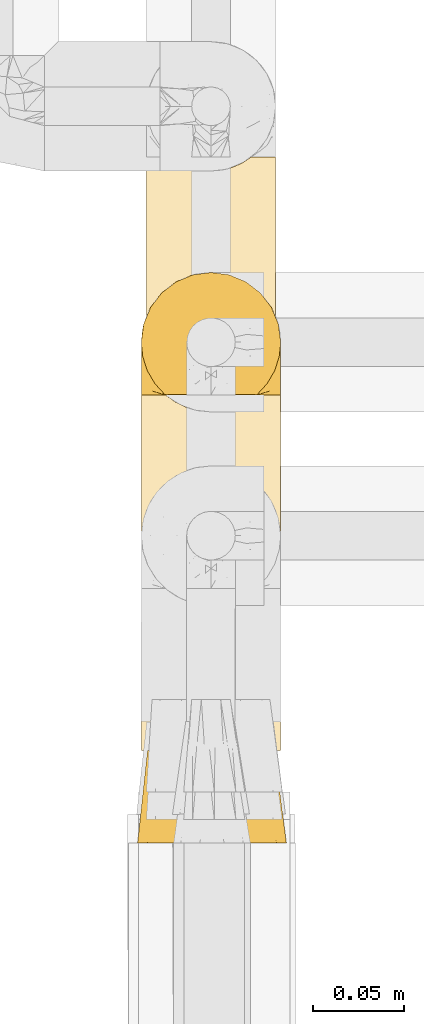
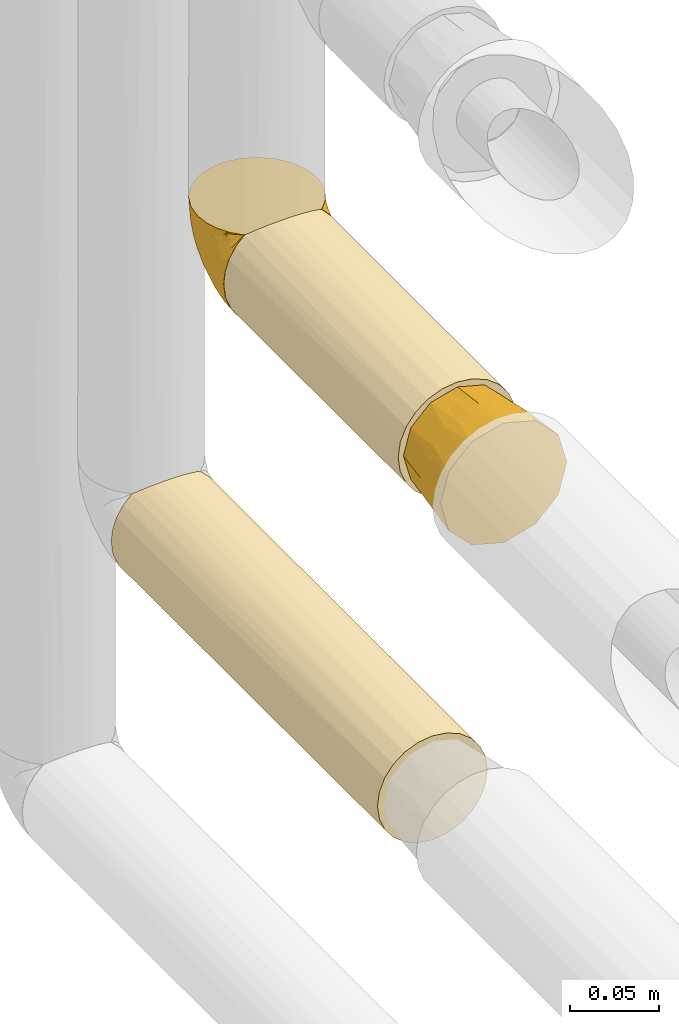
# One storey, part 78 of 827: 4 coverings.
"""IFC2X3 building model written with IfcOpenShell, lengths in millimetres."""

from ifc_helpers import new_model, entity, si_unit, converted_unit, derived_unit, direction, frame, origin, place, context, subcontext, project, spatial, faceted_brep, element, save


model = new_model("IFC2X3")

# Units and contexts
model_context = context("Model", 3, precision=0.01, world=origin(), true_north=direction((6.12303176911189e-17, 1.0)))
body_context = subcontext(model_context, "Body", "Model", "MODEL_VIEW")
ifc_project = project(units=[si_unit("LENGTHUNIT", "METRE", prefix="MILLI"), si_unit("AREAUNIT", "SQUARE_METRE"), si_unit("VOLUMEUNIT", "CUBIC_METRE"), converted_unit("PLANEANGLEUNIT", "DEGREE", entity("IfcRatioMeasure", 0.0174532925199433), si_unit("PLANEANGLEUNIT", "RADIAN"), dimensions=[0, 0, 0, 0, 0, 0, 0]), si_unit("MASSUNIT", "GRAM", prefix="KILO"), derived_unit("MASSDENSITYUNIT", [(si_unit("MASSUNIT", "GRAM", prefix="KILO"), 1), (si_unit("LENGTHUNIT", "METRE"), -3)]), derived_unit("MOMENTOFINERTIAUNIT", [(si_unit("LENGTHUNIT", "METRE"), 4)]), si_unit("TIMEUNIT", "SECOND"), si_unit("FREQUENCYUNIT", "HERTZ"), si_unit("THERMODYNAMICTEMPERATUREUNIT", "DEGREE_CELSIUS"), derived_unit("THERMALTRANSMITTANCEUNIT", [(si_unit("MASSUNIT", "GRAM", prefix="KILO"), 1), (si_unit("THERMODYNAMICTEMPERATUREUNIT", "KELVIN"), -1), (si_unit("TIMEUNIT", "SECOND"), -3)]), derived_unit("VOLUMETRICFLOWRATEUNIT", [(si_unit("LENGTHUNIT", "METRE"), 3), (si_unit("TIMEUNIT", "SECOND"), -1)]), derived_unit("MASSFLOWRATEUNIT", [(si_unit("MASSUNIT", "GRAM", prefix="KILO"), 1), (si_unit("TIMEUNIT", "SECOND"), -1)]), derived_unit("ROTATIONALFREQUENCYUNIT", [(si_unit("TIMEUNIT", "SECOND"), -1)]), si_unit("ELECTRICCURRENTUNIT", "AMPERE"), si_unit("ELECTRICVOLTAGEUNIT", "VOLT"), si_unit("POWERUNIT", "WATT"), si_unit("FORCEUNIT", "NEWTON", prefix="KILO"), si_unit("ILLUMINANCEUNIT", "LUX"), si_unit("LUMINOUSFLUXUNIT", "LUMEN"), si_unit("LUMINOUSINTENSITYUNIT", "CANDELA"), derived_unit("USERDEFINED", [(si_unit("MASSUNIT", "GRAM", prefix="KILO"), -1), (si_unit("LENGTHUNIT", "METRE"), -2), (si_unit("TIMEUNIT", "SECOND"), 3), (si_unit("LUMINOUSFLUXUNIT", "LUMEN"), 1)]), derived_unit("LINEARVELOCITYUNIT", [(si_unit("LENGTHUNIT", "METRE"), 1), (si_unit("TIMEUNIT", "SECOND"), -1)]), si_unit("PRESSUREUNIT", "PASCAL"), derived_unit("USERDEFINED", [(si_unit("LENGTHUNIT", "METRE"), -2), (si_unit("MASSUNIT", "GRAM", prefix="KILO"), 1), (si_unit("TIMEUNIT", "SECOND"), -2)]), derived_unit("LINEARFORCEUNIT", [(si_unit("MASSUNIT", "GRAM", prefix="KILO"), 1), (si_unit("LENGTHUNIT", "METRE"), 1), (si_unit("TIMEUNIT", "SECOND"), -2), (si_unit("LENGTHUNIT", "METRE"), -1)]), derived_unit("PLANARFORCEUNIT", [(si_unit("MASSUNIT", "GRAM", prefix="KILO"), 1), (si_unit("LENGTHUNIT", "METRE"), 1), (si_unit("TIMEUNIT", "SECOND"), -2), (si_unit("LENGTHUNIT", "METRE"), -2)])], contexts=[model_context])

# Site, building, storey
site_placement = place(None, origin())
site = spatial("IfcSite", under=ifc_project, at=site_placement, CompositionType="ELEMENT")
building_placement = place(site_placement, origin())
building = spatial("IfcBuilding", under=site, at=building_placement, CompositionType="ELEMENT")
storey_placement = place(building_placement, frame((0.0, 0.0, 28200.0)))
storey = spatial("IfcBuildingStorey", under=building, at=storey_placement, Name="08", CompositionType="ELEMENT", Elevation=28200.0)

# Coverings
covering_1_placement = place(storey_placement, frame((17886.73, 11641.18, 1062.52)))
element("IfcCovering", 1, at=covering_1_placement, inside=storey, Name=":ADSK_", ObjectType=":ADSK_", PredefinedType="INSULATION", context=body_context, shape_type="Brep", body=[
    faceted_brep([(5.09, 195.9, 56.01), (9.31, 195.9, 63.08), (14.94, 195.9, 69.1), (65.05, 195.9, 69.1), (70.68, 195.9, 63.08), (74.9, 195.9, 56.01), (77.51, 195.9, 48.2), (78.4, 195.9, 40.0), (77.09, 195.9, 30.06), (73.25, 195.9, 20.8), (67.15, 195.9, 12.84), (59.2, 195.9, 6.74), (49.93, 195.9, 2.9), (40.0, 195.9, 1.6), (30.06, 195.9, 2.9), (20.8, 195.9, 6.74), (12.84, 195.9, 12.84), (6.74, 195.9, 20.8), (2.9, 195.9, 30.06), (1.6, 195.9, 40.0), (2.48, 195.9, 48.2), (20.8, 0.0, 73.25), (12.84, 0.0, 67.15), (6.74, 0.0, 59.2), (2.9, 0.0, 49.93), (1.6, 0.0, 40.0), (2.9, 0.0, 30.06), (6.74, 0.0, 20.8), (12.84, 0.0, 12.84), (20.8, 0.0, 6.74), (30.06, 0.0, 2.9), (40.0, 0.0, 1.6), (49.93, 0.0, 2.9), (59.2, 0.0, 6.74), (67.15, 0.0, 12.84), (73.25, 0.0, 20.8), (77.09, 0.0, 30.06), (78.4, 0.0, 40.0), (77.09, 0.0, 49.93), (73.25, 0.0, 59.2), (67.15, 0.0, 67.15), (59.2, 0.0, 73.25), (49.93, 0.0, 77.09), (40.0, 0.0, 78.4), (30.06, 0.0, 77.09), (26.63, 189.0, 76.0), (33.21, 187.2, 77.79), (40.0, 186.6, 78.4), (20.48, 191.93, 73.07), (46.78, 187.2, 77.79), (53.36, 189.0, 76.0), (59.51, 191.93, 73.07)], [[[0, 1, 2, 3, 4, 5, 6, 7, 8, 9, 10, 11, 12, 13, 14, 15, 16, 17, 18, 19, 20]], [[21, 22, 23, 24, 25, 26, 27, 28, 29, 30, 31, 32, 33, 34, 35, 36, 37, 38, 39, 40, 41, 42, 43, 44]], [[36, 35, 9, 8]], [[37, 36, 8, 7]], [[35, 34, 10, 9]], [[12, 11, 33, 32]], [[13, 12, 32, 31]], [[34, 33, 11, 10]], [[14, 13, 31, 30]], [[15, 14, 30, 29]], [[29, 28, 16, 15]], [[18, 17, 27, 26]], [[19, 18, 26, 25]], [[28, 27, 17, 16]], [[20, 25, 24]], [[0, 24, 23]], [[1, 23, 22]], [[19, 25, 20]], [[20, 24, 0]], [[23, 1, 0]], [[22, 2, 1]], [[45, 21, 44]], [[44, 43, 46]], [[47, 46, 43]], [[48, 2, 21]], [[46, 45, 44]], [[48, 21, 45]], [[21, 2, 22]], [[49, 47, 43]], [[49, 43, 42]], [[50, 42, 41]], [[50, 49, 42]], [[3, 51, 41]], [[50, 41, 51]], [[41, 40, 3]], [[4, 40, 39]], [[5, 39, 38]], [[6, 38, 37]], [[4, 39, 5]], [[5, 38, 6]], [[37, 7, 6]], [[40, 4, 3]], [[48, 45, 46, 47, 49, 50, 51, 3, 2]]]),
])
covering_2_placement = place(storey_placement, frame((17886.68, 11835.48, 1062.47)))
element("IfcCovering", 2, at=covering_2_placement, inside=storey, Name=":ADSK_", ObjectType=":ADSK_", PredefinedType="INSULATION", context=body_context, shape_type="Brep", body=[
    faceted_brep([(5.41, 1.6, 23.36), (9.99, 1.6, 16.07), (16.08, 1.6, 9.98), (23.37, 1.6, 5.4), (31.49, 1.6, 2.56), (40.05, 1.6, 1.6), (48.61, 1.6, 2.56), (56.73, 1.6, 5.41), (64.02, 1.6, 9.99), (70.11, 1.6, 16.08), (74.69, 1.6, 23.37), (77.53, 1.6, 31.49), (78.5, 1.6, 40.05), (77.63, 1.6, 48.15), (75.08, 1.6, 55.88), (70.97, 1.6, 62.9), (65.47, 1.6, 68.89), (63.27, 1.6, 68.89), (61.53, 1.6, 68.89), (59.57, 1.6, 68.89), (57.6, 1.6, 68.89), (55.63, 1.6, 68.89), (53.67, 1.6, 68.89), (51.7, 1.6, 68.89), (49.73, 1.6, 68.89), (47.54, 1.6, 68.89), (45.34, 1.6, 68.89), (43.15, 1.6, 68.89), (40.96, 1.6, 68.89), (38.76, 1.6, 68.89), (36.57, 1.6, 68.89), (34.37, 1.6, 68.89), (32.18, 1.6, 68.89), (29.98, 1.6, 68.89), (27.79, 1.6, 68.89), (25.6, 1.6, 68.89), (23.4, 1.6, 68.89), (21.21, 1.6, 68.89), (19.01, 1.6, 68.89), (16.82, 1.6, 68.89), (14.62, 1.6, 68.89), (9.12, 1.6, 62.89), (5.0, 1.6, 55.86), (2.46, 1.6, 48.13), (1.6, 1.6, 40.05), (2.56, 1.6, 31.49), (65.47, 1.85, 69.15), (70.97, 7.85, 69.15), (75.09, 14.87, 69.15), (77.63, 22.6, 69.15), (78.5, 30.7, 69.15), (77.19, 40.65, 69.15), (73.34, 49.92, 69.15), (67.23, 57.88, 69.15), (59.27, 63.99, 69.15), (50.0, 67.84, 69.15), (40.05, 69.15, 69.15), (30.09, 67.84, 69.15), (20.82, 63.99, 69.15), (12.86, 57.88, 69.15), (6.75, 49.92, 69.15), (2.91, 40.65, 69.15), (1.6, 30.7, 69.15), (2.46, 22.6, 69.15), (5.0, 14.87, 69.15), (9.12, 7.85, 69.15), (14.62, 1.85, 69.15), (16.82, 1.85, 69.15), (17.8, 1.85, 69.15), (19.39, 1.85, 69.15), (20.98, 1.85, 69.15), (22.57, 1.85, 69.15), (24.16, 1.85, 69.15), (25.75, 1.85, 69.15), (27.33, 1.85, 69.15), (28.92, 1.85, 69.15), (30.51, 1.85, 69.15), (32.1, 1.85, 69.15), (33.69, 1.85, 69.15), (35.28, 1.85, 69.15), (36.87, 1.85, 69.15), (38.46, 1.85, 69.15), (40.05, 1.85, 69.15), (41.63, 1.85, 69.15), (43.22, 1.85, 69.15), (44.81, 1.85, 69.15), (46.4, 1.85, 69.15), (47.99, 1.85, 69.15), (49.58, 1.85, 69.15), (51.17, 1.85, 69.15), (52.76, 1.85, 69.15), (54.72, 1.85, 69.15), (56.69, 1.85, 69.15), (58.88, 1.85, 69.15), (61.08, 1.85, 69.15), (63.27, 1.85, 69.15), (37.77, 1.77, 68.96), (36.07, 1.78, 68.97), (32.96, 1.77, 68.97), (31.36, 1.77, 68.97), (56.52, 1.76, 68.95), (54.96, 1.77, 68.96), (18.75, 1.79, 68.98), (58.07, 1.78, 68.97), (50.37, 1.78, 68.97), (23.36, 1.78, 68.98), (24.95, 1.78, 68.97), (42.43, 1.78, 68.97), (15.97, 1.74, 68.94), (51.96, 1.78, 68.98), (53.47, 1.78, 68.98), (48.63, 1.77, 68.96), (63.93, 1.78, 68.97), (40.93, 1.78, 68.98), (29.72, 1.78, 68.98), (62.4, 1.77, 68.97), (60.92, 1.77, 68.96), (17.31, 1.77, 68.97), (21.74, 1.78, 68.97), (34.56, 1.78, 68.98), (20.18, 1.77, 68.96), (14.62, 1.77, 68.97), (14.62, 1.72, 68.94), (14.62, 1.66, 68.92), (65.47, 1.77, 68.97), (65.47, 1.8, 69.02), (59.5, 1.79, 68.98), (47.1, 1.78, 68.97), (45.61, 1.79, 68.98), (28.18, 1.78, 68.97), (14.62, 1.82, 69.08), (26.61, 1.76, 68.96), (65.47, 1.66, 68.92), (65.47, 1.72, 68.94), (39.32, 1.78, 68.97), (44.12, 1.77, 68.96), (65.47, 1.82, 69.08), (72.26, 9.41, 67.02), (76.57, 17.65, 63.33), (71.77, 7.41, 64.61), (77.9, 15.21, 51.4), (76.56, 7.41, 53.1), (78.5, 16.15, 43.94), (78.5, 28.75, 61.87), (75.52, 13.67, 61.54), (76.13, 12.79, 57.95), (77.81, 19.18, 56.12), (78.5, 29.16, 63.4), (72.4, 9.04, 65.41), (71.77, 5.74, 63.04), (72.25, 3.72, 61.33), (78.5, 8.87, 41.99), (78.5, 21.47, 49.27), (78.5, 26.8, 54.6), (75.75, 9.53, 56.6), (78.5, 7.34, 41.58), (50.46, 37.63, 13.72), (52.75, 17.92, 5.82), (40.05, 27.45, 6.74), (77.7, 37.01, 58.82), (77.66, 34.22, 51.58), (71.02, 45.87, 42.09), (63.45, 56.57, 46.12), (70.55, 52.31, 55.56), (75.57, 42.07, 52.38), (75.57, 44.74, 61.54), (72.61, 21.49, 23.76), (72.61, 11.02, 20.5), (67.24, 15.64, 14.64), (77.74, 26.02, 41.77), (57.43, 36.59, 16.28), (47.19, 65.49, 49.4), (54.76, 63.99, 52.34), (40.05, 15.2, 4.3), (63.45, 60.27, 58.67), (60.1, 45.25, 25.26), (63.72, 35.21, 20.17), (76.83, 22.52, 34.7), (76.34, 12.03, 28.67), (60.51, 13.32, 8.62), (72.59, 35.9, 33.37), (76.05, 33.87, 41.35), (66.15, 25.73, 17.15), (60.51, 26.34, 12.68), (51.88, 46.78, 21.47), (55.34, 59.54, 41.11), (48.67, 60.18, 37.53), (53.89, 53.93, 30.64), (46.73, 53.36, 26.66), (40.05, 49.36, 21.38), (40.05, 38.4, 14.06), (40.05, 66.44, 55.54), (63.95, 50.09, 35.17), (67.24, 41.08, 29.04), (69.62, 31.14, 24.34), (73.6, 28.19, 29.33), (40.05, 64.0, 43.3), (40.05, 56.68, 32.34), (4.52, 43.9, 57.75), (32.72, 65.46, 49.41), (27.18, 52.22, 27.85), (29.63, 37.61, 13.7), (12.86, 15.64, 14.63), (19.59, 13.31, 8.61), (9.54, 50.02, 48.85), (16.64, 59.28, 54.13), (17.48, 53.05, 37.84), (7.49, 21.48, 23.75), (7.49, 11.01, 20.49), (3.75, 12.03, 28.66), (20.75, 41.02, 20.83), (2.33, 35.39, 55.15), (1.6, 26.8, 54.6), (1.6, 28.75, 61.87), (1.6, 7.34, 41.58), (26.94, 65.81, 57.58), (9.54, 53.28, 59.91), (31.21, 59.8, 36.94), (25.33, 61.82, 45.72), (27.35, 17.91, 5.82), (8.17, 41.4, 37.91), (4.3, 40.48, 50.18), (19.59, 26.34, 12.67), (2.23, 31.68, 49.29), (2.45, 27.68, 42.64), (1.6, 16.15, 43.94), (1.6, 21.47, 49.27), (12.86, 28.05, 19.45), (3.27, 22.54, 34.7), (1.6, 8.87, 41.99), (2.29, 37.3, 62.29), (12.86, 41.07, 29.01), (6.89, 32.24, 31.47), (12.43, 47.4, 37.18), (4.1, 35.77, 43.45), (3.53, 17.65, 63.33), (6.88, 11.06, 67.23), (8.16, 8.55, 66.07), (14.62, 1.8, 69.02), (9.02, 6.63, 65.22), (5.0, 12.77, 61.99), (3.96, 12.79, 57.95), (3.52, 7.41, 53.09), (2.4, 18.97, 56.84), (7.83, 3.72, 61.33), (8.32, 5.76, 63.06), (2.19, 15.21, 51.41), (4.34, 9.52, 56.61)], [[[0, 1, 2, 3, 4, 5, 6, 7, 8, 9, 10, 11, 12, 13, 14, 15, 16, 17, 18, 19, 20, 21, 22, 23, 24, 25, 26, 27, 28, 29, 30, 31, 32, 33, 34, 35, 36, 37, 38, 39, 40, 41, 42, 43, 44, 45]], [[46, 47, 48, 49, 50, 51, 52, 53, 54, 55, 56, 57, 58, 59, 60, 61, 62, 63, 64, 65, 66, 67, 68, 69, 70, 71, 72, 73, 74, 75, 76, 77, 78, 79, 80, 81, 82, 83, 84, 85, 86, 87, 88, 89, 90, 91, 92, 93, 94, 95]], [[96, 97, 30]], [[98, 77, 99]], [[100, 101, 21]], [[69, 68, 102]], [[20, 19, 103]], [[24, 23, 104]], [[20, 103, 100]], [[72, 105, 106]], [[84, 83, 107]], [[89, 88, 104]], [[108, 67, 66]], [[109, 110, 90]], [[111, 25, 24]], [[112, 17, 16]], [[82, 113, 83]], [[109, 23, 22]], [[114, 76, 75]], [[105, 36, 106]], [[104, 111, 24]], [[18, 115, 116]], [[97, 96, 80]], [[67, 108, 117]], [[105, 71, 118]], [[31, 97, 119]], [[102, 120, 69]], [[108, 121, 122, 123, 40]], [[112, 95, 115]], [[17, 115, 18]], [[94, 116, 115]], [[117, 68, 67]], [[38, 117, 39]], [[112, 124, 125]], [[17, 112, 115]], [[70, 120, 118]], [[39, 117, 108]], [[120, 38, 37]], [[120, 37, 118]], [[120, 70, 69]], [[116, 94, 126]], [[127, 86, 128]], [[117, 38, 102]], [[74, 129, 75]], [[99, 33, 32]], [[115, 95, 94]], [[39, 108, 40]], [[108, 66, 130]], [[105, 72, 71]], [[118, 37, 36]], [[71, 70, 118]], [[35, 106, 36]], [[36, 105, 118]], [[35, 131, 106]], [[74, 73, 131]], [[106, 131, 73]], [[99, 114, 33]], [[131, 35, 34]], [[73, 72, 106]], [[95, 112, 46]], [[112, 16, 132, 133, 124]], [[129, 114, 75]], [[99, 76, 114]], [[114, 129, 33]], [[34, 33, 129]], [[78, 77, 98]], [[98, 119, 78]], [[129, 131, 34]], [[131, 129, 74]], [[79, 97, 80]], [[98, 99, 32]], [[98, 32, 31]], [[77, 76, 99]], [[97, 79, 119]], [[134, 96, 29]], [[30, 97, 31]], [[134, 29, 28]], [[81, 80, 96]], [[29, 96, 30]], [[31, 119, 98]], [[119, 79, 78]], [[96, 134, 81]], [[82, 81, 134]], [[113, 107, 83]], [[84, 107, 135]], [[107, 27, 135]], [[113, 28, 107]], [[27, 107, 28]], [[85, 84, 135]], [[135, 27, 26]], [[113, 134, 28]], [[134, 113, 82]], [[109, 89, 104]], [[86, 85, 128]], [[89, 109, 90]], [[111, 87, 127]], [[26, 128, 135]], [[88, 111, 104]], [[25, 111, 127]], [[22, 110, 109]], [[23, 109, 104]], [[110, 91, 90]], [[100, 92, 101]], [[110, 22, 101]], [[91, 110, 101]], [[116, 19, 18]], [[111, 88, 87]], [[126, 103, 19]], [[25, 127, 26]], [[86, 127, 87]], [[127, 128, 26]], [[135, 128, 85]], [[120, 102, 38]], [[117, 102, 68]], [[91, 101, 92]], [[21, 101, 22]], [[93, 92, 103]], [[100, 21, 20]], [[100, 103, 92]], [[126, 93, 103]], [[93, 126, 94]], [[116, 126, 19]], [[136, 137, 47]], [[48, 137, 138]], [[139, 125, 124]], [[140, 141, 142]], [[143, 49, 138]], [[144, 139, 145]], [[48, 138, 49]], [[138, 144, 146]], [[49, 143, 147, 50]], [[136, 125, 148]], [[14, 13, 141]], [[149, 145, 139]], [[148, 139, 144]], [[150, 149, 133]], [[150, 14, 141]], [[16, 15, 132]], [[13, 151, 141]], [[124, 149, 139]], [[140, 142, 152]], [[14, 150, 15]], [[15, 150, 132]], [[47, 46, 136]], [[138, 153, 143]], [[137, 48, 47]], [[125, 139, 148]], [[133, 132, 150]], [[145, 154, 140]], [[144, 145, 146]], [[148, 138, 137]], [[146, 152, 153]], [[146, 145, 140]], [[138, 146, 153]], [[138, 148, 144]], [[148, 137, 136]], [[146, 140, 152]], [[145, 149, 154]], [[150, 154, 149]], [[141, 140, 154]], [[13, 12, 155, 151]], [[151, 142, 141]], [[150, 141, 154]], [[149, 124, 133]], [[156, 157, 158]], [[159, 153, 160]], [[161, 162, 163]], [[164, 165, 159]], [[166, 167, 168]], [[152, 169, 160]], [[155, 12, 11]], [[157, 156, 170]], [[171, 55, 172]], [[157, 6, 173]], [[174, 54, 53]], [[52, 165, 163]], [[52, 163, 53]], [[54, 174, 172]], [[165, 52, 51]], [[175, 176, 170]], [[177, 142, 178]], [[155, 11, 178]], [[8, 7, 179]], [[168, 9, 8]], [[178, 142, 151, 155]], [[178, 11, 10]], [[167, 178, 10]], [[180, 161, 181]], [[178, 166, 177]], [[182, 183, 176]], [[182, 168, 183]], [[175, 170, 184]], [[171, 185, 186]], [[157, 7, 6]], [[158, 157, 173]], [[183, 179, 157]], [[54, 172, 55]], [[179, 168, 8]], [[187, 188, 186]], [[9, 167, 10]], [[185, 187, 186]], [[189, 156, 158, 190]], [[55, 171, 191]], [[175, 192, 193]], [[160, 169, 181]], [[161, 163, 164]], [[174, 163, 162]], [[51, 50, 147]], [[166, 194, 195]], [[177, 181, 169]], [[6, 5, 173]], [[157, 179, 7]], [[168, 179, 183]], [[168, 167, 9]], [[178, 167, 166]], [[181, 161, 164]], [[161, 193, 192]], [[160, 164, 159]], [[194, 180, 195]], [[191, 171, 196]], [[191, 56, 55]], [[188, 189, 197]], [[197, 196, 186]], [[171, 186, 196]], [[184, 188, 187]], [[197, 186, 188]], [[185, 171, 172]], [[172, 162, 185]], [[192, 185, 162]], [[175, 184, 187]], [[184, 156, 189]], [[187, 185, 192]], [[176, 175, 193]], [[187, 192, 175]], [[161, 192, 162]], [[194, 176, 193]], [[170, 176, 183]], [[180, 194, 193]], [[182, 166, 168]], [[161, 180, 193]], [[195, 181, 177]], [[157, 170, 183]], [[170, 156, 184]], [[176, 194, 182]], [[166, 182, 194]], [[181, 195, 180]], [[177, 169, 142]], [[177, 166, 195]], [[163, 174, 53]], [[172, 174, 162]], [[159, 51, 147]], [[163, 165, 164]], [[51, 159, 165]], [[159, 147, 143, 153]], [[152, 160, 153]], [[181, 164, 160]], [[189, 188, 184]], [[142, 169, 152]], [[60, 198, 61]], [[196, 199, 191]], [[200, 189, 201]], [[199, 57, 191]], [[202, 203, 2]], [[204, 205, 206]], [[207, 208, 209]], [[210, 206, 200]], [[211, 212, 213]], [[45, 214, 209]], [[215, 205, 58]], [[45, 44, 214]], [[59, 216, 60]], [[60, 216, 198]], [[0, 45, 209]], [[217, 200, 218]], [[201, 158, 219]], [[204, 220, 221]], [[222, 203, 202]], [[1, 202, 2]], [[57, 199, 215]], [[219, 3, 203]], [[219, 173, 4]], [[1, 0, 208]], [[211, 223, 212]], [[224, 225, 226]], [[227, 222, 202]], [[207, 209, 228]], [[209, 225, 228]], [[3, 219, 4]], [[58, 205, 59]], [[208, 202, 1]], [[201, 219, 222]], [[227, 202, 207]], [[201, 210, 200]], [[3, 2, 203]], [[201, 189, 190, 158]], [[209, 214, 229, 225]], [[198, 211, 230]], [[231, 232, 220]], [[232, 207, 228]], [[206, 205, 218]], [[216, 205, 204]], [[226, 223, 224]], [[232, 231, 227]], [[200, 206, 218]], [[233, 231, 220]], [[217, 218, 199]], [[201, 222, 210]], [[173, 219, 158]], [[173, 5, 4]], [[61, 230, 62]], [[219, 203, 222]], [[209, 208, 0]], [[202, 208, 207]], [[224, 232, 228]], [[223, 226, 212]], [[220, 232, 234]], [[57, 56, 191]], [[197, 217, 196]], [[199, 218, 215]], [[200, 197, 189]], [[196, 217, 199]], [[197, 200, 217]], [[205, 215, 218]], [[58, 57, 215]], [[230, 211, 213]], [[221, 211, 198]], [[227, 210, 222]], [[206, 210, 231]], [[62, 230, 213]], [[198, 230, 61]], [[232, 227, 207]], [[210, 227, 231]], [[221, 220, 234]], [[233, 204, 206]], [[205, 216, 59]], [[198, 216, 204]], [[204, 221, 198]], [[223, 221, 234]], [[221, 223, 211]], [[223, 234, 224]], [[232, 224, 234]], [[225, 224, 228]], [[204, 233, 220]], [[206, 231, 233]], [[63, 213, 235]], [[213, 212, 235]], [[213, 63, 62]], [[236, 235, 237]], [[237, 238, 130]], [[235, 236, 64]], [[239, 240, 241]], [[63, 235, 64]], [[130, 66, 65]], [[236, 130, 65]], [[242, 229, 43]], [[236, 65, 64]], [[239, 121, 238]], [[42, 242, 43]], [[241, 240, 243]], [[41, 123, 244]], [[43, 229, 214, 44]], [[244, 122, 245]], [[226, 246, 243]], [[241, 247, 245]], [[121, 239, 245]], [[41, 40, 123]], [[238, 237, 239]], [[244, 42, 41]], [[130, 236, 237]], [[240, 239, 237]], [[245, 239, 241]], [[247, 241, 246]], [[247, 244, 245]], [[237, 235, 240]], [[243, 235, 212]], [[235, 243, 240]], [[226, 225, 246]], [[243, 212, 226]], [[242, 246, 225]], [[243, 246, 241]], [[246, 242, 247]], [[244, 247, 242]], [[242, 225, 229]], [[42, 244, 242]], [[122, 244, 123]], [[122, 121, 245]], [[112, 125, 136, 46]], [[108, 130, 238]], [[108, 238, 121]]]),
])
covering_3_placement = place(storey_placement, frame((17884.68, 11590.18, 1059.92)))
element("IfcCovering", 3, at=covering_3_placement, inside=storey, Name=":ADSK_", ObjectType=":ADSK_", PredefinedType="INSULATION", context=body_context, shape_type="Brep", body=[
    faceted_brep([(74.7, 51.0, 51.35), (77.04, 51.0, 42.6), (74.7, 51.0, 33.85), (72.35, 51.0, 25.1), (65.95, 51.0, 18.69), (59.54, 51.0, 12.28), (50.79, 51.0, 9.94), (42.04, 51.0, 7.6), (33.29, 51.0, 9.94), (24.54, 51.0, 12.28), (18.14, 51.0, 18.69), (11.73, 51.0, 25.1), (9.39, 51.0, 33.85), (7.04, 51.0, 42.6), (9.39, 51.0, 51.35), (11.73, 51.0, 60.1), (18.14, 51.0, 66.5), (24.54, 51.0, 72.91), (33.29, 51.0, 75.25), (42.04, 51.0, 77.6), (50.79, 51.0, 75.25), (59.54, 51.0, 72.91), (65.95, 51.0, 66.5), (72.35, 51.0, 60.1), (22.1, 0.0, 78.1), (14.59, 0.0, 70.6), (7.09, 0.0, 63.1), (3.79, 0.0, 50.78), (1.6, 0.0, 42.6), (4.34, 0.0, 32.35), (7.09, 0.0, 22.1), (14.59, 0.0, 14.59), (22.1, 0.0, 7.09), (34.41, 0.0, 3.79), (42.6, 0.0, 1.6), (52.85, 0.0, 4.34), (63.1, 0.0, 7.09), (70.6, 0.0, 14.59), (78.1, 0.0, 22.1), (81.4, 0.0, 34.41), (83.6, 0.0, 42.6), (80.85, 0.0, 52.85), (78.1, 0.0, 63.1), (70.6, 0.0, 70.6), (63.1, 0.0, 78.1), (50.78, 0.0, 81.4), (42.6, 0.0, 83.6), (32.35, 0.0, 80.85), (77.43, 25.5, 28.05), (79.45, 26.64, 35.21), (73.64, 25.5, 21.08), (42.3, 27.48, 4.83), (65.45, 25.5, 12.45), (58.69, 25.5, 8.3), (80.07, 27.48, 42.6), (51.76, 25.5, 5.79), (27.78, 25.5, 7.49), (34.92, 26.64, 5.46), (20.81, 25.5, 11.27), (4.53, 27.5, 42.6), (12.17, 25.5, 19.46), (8.03, 25.5, 26.22), (5.51, 25.5, 33.15), (7.21, 25.5, 57.14), (5.17, 26.64, 49.98), (11.0, 25.5, 64.11), (42.3, 27.5, 80.36), (19.19, 25.5, 72.74), (25.95, 25.5, 76.89), (32.87, 25.5, 79.4), (56.86, 25.5, 77.7), (49.7, 26.64, 79.73), (63.83, 25.5, 73.92), (72.47, 25.5, 65.73), (76.61, 25.5, 58.97), (79.13, 25.5, 52.04)], [[[0, 1, 2, 3, 4, 5, 6, 7, 8, 9, 10, 11, 12, 13, 14, 15, 16, 17, 18, 19, 20, 21, 22, 23]], [[24, 25, 26, 27, 28, 29, 30, 31, 32, 33, 34, 35, 36, 37, 38, 39, 40, 41, 42, 43, 44, 45, 46, 47]], [[39, 48, 49]], [[49, 40, 39]], [[48, 39, 38]], [[3, 2, 48]], [[50, 3, 48]], [[48, 2, 49]], [[51, 7, 6]], [[52, 50, 37]], [[50, 48, 38]], [[5, 52, 53]], [[53, 52, 36]], [[37, 36, 52]], [[50, 38, 37]], [[54, 40, 49, 1]], [[52, 4, 50]], [[4, 3, 50]], [[4, 52, 5]], [[55, 6, 53]], [[53, 35, 55]], [[53, 36, 35]], [[1, 49, 2]], [[6, 5, 53]], [[34, 51, 55]], [[34, 55, 35]], [[51, 6, 55]], [[33, 56, 57]], [[57, 34, 33]], [[56, 33, 32]], [[9, 8, 56]], [[58, 9, 56]], [[56, 8, 57]], [[59, 13, 12]], [[60, 58, 31]], [[58, 56, 32]], [[11, 60, 61]], [[61, 60, 30]], [[31, 30, 60]], [[58, 32, 31]], [[51, 34, 57, 7]], [[60, 10, 58]], [[10, 9, 58]], [[10, 60, 11]], [[62, 12, 61]], [[61, 29, 62]], [[61, 30, 29]], [[7, 57, 8]], [[12, 11, 61]], [[28, 59, 62]], [[28, 62, 29]], [[59, 12, 62]], [[27, 63, 64]], [[64, 28, 27]], [[63, 27, 26]], [[15, 14, 63]], [[65, 15, 63]], [[63, 14, 64]], [[66, 19, 18]], [[67, 65, 25]], [[65, 63, 26]], [[17, 67, 68]], [[68, 67, 24]], [[25, 24, 67]], [[65, 26, 25]], [[59, 28, 64, 13]], [[67, 16, 65]], [[16, 15, 65]], [[16, 67, 17]], [[69, 18, 68]], [[68, 47, 69]], [[68, 24, 47]], [[13, 64, 14]], [[18, 17, 68]], [[46, 66, 69]], [[46, 69, 47]], [[66, 18, 69]], [[45, 70, 71]], [[71, 46, 45]], [[70, 45, 44]], [[21, 20, 70]], [[72, 21, 70]], [[70, 20, 71]], [[54, 1, 0]], [[73, 72, 43]], [[72, 70, 44]], [[23, 73, 74]], [[74, 73, 42]], [[43, 42, 73]], [[72, 44, 43]], [[66, 46, 71, 19]], [[73, 22, 72]], [[22, 21, 72]], [[22, 73, 23]], [[75, 0, 74]], [[74, 41, 75]], [[74, 42, 41]], [[19, 71, 20]], [[0, 23, 74]], [[40, 54, 75]], [[40, 75, 41]], [[54, 0, 75]]]),
])
covering_4_placement = place(storey_placement, frame((17889.48, 11669.2, 808.5)))
element("IfcCovering", 4, at=covering_4_placement, inside=storey, Name=":ADSK_", ObjectType=":ADSK_", PredefinedType="INSULATION", context=body_context, shape_type="Brep", body=[
    faceted_brep([(5.17, 299.0, 52.81), (9.47, 299.0, 59.6), (15.18, 299.0, 65.25), (59.31, 299.0, 65.25), (65.02, 299.0, 59.6), (69.32, 299.0, 52.81), (71.99, 299.0, 45.24), (72.9, 299.0, 37.25), (71.68, 299.0, 28.02), (68.12, 299.0, 19.42), (62.45, 299.0, 12.04), (55.07, 299.0, 6.37), (46.47, 299.0, 2.81), (37.25, 299.0, 1.6), (28.02, 299.0, 2.81), (19.42, 299.0, 6.37), (12.04, 299.0, 12.04), (6.37, 299.0, 19.42), (2.81, 299.0, 28.02), (1.6, 299.0, 37.25), (2.5, 299.0, 45.24), (28.02, 0.0, 71.68), (19.42, 0.0, 68.12), (12.04, 0.0, 62.45), (6.37, 0.0, 55.07), (2.81, 0.0, 46.47), (1.6, 0.0, 37.25), (2.81, 0.0, 28.02), (6.37, 0.0, 19.42), (12.04, 0.0, 12.04), (19.42, 0.0, 6.37), (28.02, 0.0, 2.81), (37.25, 0.0, 1.6), (46.47, 0.0, 2.81), (55.07, 0.0, 6.37), (62.45, 0.0, 12.04), (68.12, 0.0, 19.42), (71.68, 0.0, 28.02), (72.9, 0.0, 37.25), (71.68, 0.0, 46.47), (68.12, 0.0, 55.07), (62.45, 0.0, 62.45), (55.07, 0.0, 68.12), (46.47, 0.0, 71.68), (37.25, 0.0, 72.9), (25.57, 293.32, 70.93), (31.32, 291.85, 72.4), (37.25, 291.35, 72.9), (20.14, 295.72, 68.52), (43.17, 291.85, 72.4), (48.92, 293.32, 70.93), (54.35, 295.72, 68.52)], [[[0, 1, 2, 3, 4, 5, 6, 7, 8, 9, 10, 11, 12, 13, 14, 15, 16, 17, 18, 19, 20]], [[21, 22, 23, 24, 25, 26, 27, 28, 29, 30, 31, 32, 33, 34, 35, 36, 37, 38, 39, 40, 41, 42, 43, 44]], [[37, 36, 9, 8]], [[38, 37, 8, 7]], [[10, 9, 36, 35]], [[12, 11, 34, 33]], [[13, 12, 33, 32]], [[35, 34, 11, 10]], [[14, 13, 32, 31]], [[15, 14, 31, 30]], [[30, 29, 16, 15]], [[18, 17, 28, 27]], [[19, 18, 27, 26]], [[29, 28, 17, 16]], [[20, 26, 25]], [[0, 25, 24]], [[1, 24, 23]], [[19, 26, 20]], [[20, 25, 0]], [[24, 1, 0]], [[23, 2, 1]], [[45, 22, 21]], [[21, 44, 46]], [[47, 46, 44]], [[48, 2, 22]], [[46, 45, 21]], [[48, 22, 45]], [[22, 2, 23]], [[49, 47, 44]], [[49, 44, 43]], [[50, 43, 42]], [[50, 49, 43]], [[3, 51, 42]], [[50, 42, 51]], [[42, 41, 3]], [[4, 41, 40]], [[5, 40, 39]], [[6, 39, 38]], [[4, 40, 5]], [[5, 39, 6]], [[38, 7, 6]], [[41, 4, 3]], [[48, 45, 46, 47, 49, 50, 51, 3, 2]]]),
])

save(model, "model.ifc")
